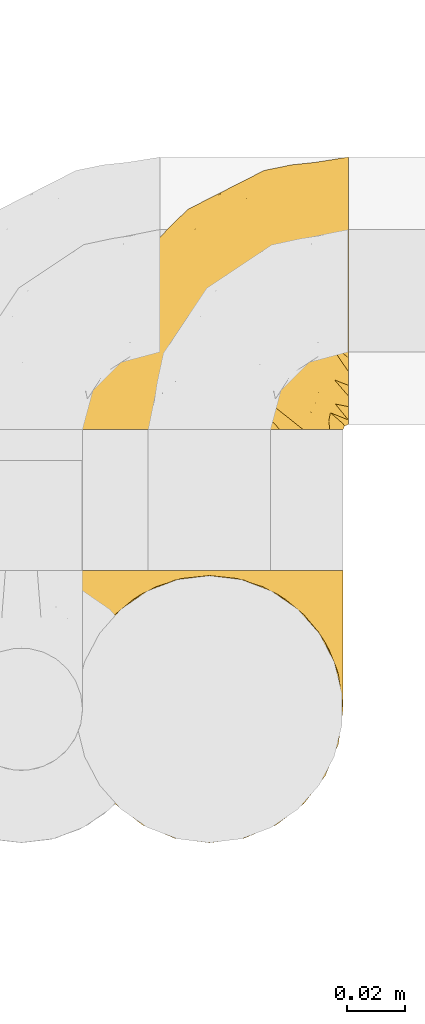
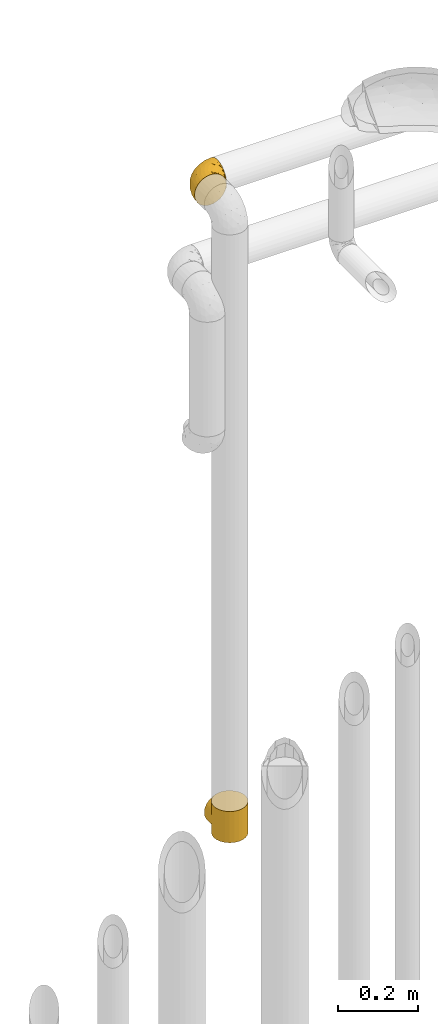
# One storey, part 511 of 827: 2 coverings.
"""IFC2X3 building model written with IfcOpenShell, lengths in millimetres."""

from ifc_helpers import new_model, entity, si_unit, converted_unit, derived_unit, direction, frame, origin, place, context, subcontext, project, spatial, faceted_brep, element, save


model = new_model("IFC2X3")

# Units and contexts
model_context = context("Model", 3, precision=0.01, world=origin(), true_north=direction((6.12303176911189e-17, 1.0)))
body_context = subcontext(model_context, "Body", "Model", "MODEL_VIEW")
ifc_project = project(units=[si_unit("LENGTHUNIT", "METRE", prefix="MILLI"), si_unit("AREAUNIT", "SQUARE_METRE"), si_unit("VOLUMEUNIT", "CUBIC_METRE"), converted_unit("PLANEANGLEUNIT", "DEGREE", entity("IfcRatioMeasure", 0.0174532925199433), si_unit("PLANEANGLEUNIT", "RADIAN"), dimensions=[0, 0, 0, 0, 0, 0, 0]), si_unit("MASSUNIT", "GRAM", prefix="KILO"), derived_unit("MASSDENSITYUNIT", [(si_unit("MASSUNIT", "GRAM", prefix="KILO"), 1), (si_unit("LENGTHUNIT", "METRE"), -3)]), derived_unit("MOMENTOFINERTIAUNIT", [(si_unit("LENGTHUNIT", "METRE"), 4)]), si_unit("TIMEUNIT", "SECOND"), si_unit("FREQUENCYUNIT", "HERTZ"), si_unit("THERMODYNAMICTEMPERATUREUNIT", "DEGREE_CELSIUS"), derived_unit("THERMALTRANSMITTANCEUNIT", [(si_unit("MASSUNIT", "GRAM", prefix="KILO"), 1), (si_unit("THERMODYNAMICTEMPERATUREUNIT", "KELVIN"), -1), (si_unit("TIMEUNIT", "SECOND"), -3)]), derived_unit("VOLUMETRICFLOWRATEUNIT", [(si_unit("LENGTHUNIT", "METRE"), 3), (si_unit("TIMEUNIT", "SECOND"), -1)]), derived_unit("MASSFLOWRATEUNIT", [(si_unit("MASSUNIT", "GRAM", prefix="KILO"), 1), (si_unit("TIMEUNIT", "SECOND"), -1)]), derived_unit("ROTATIONALFREQUENCYUNIT", [(si_unit("TIMEUNIT", "SECOND"), -1)]), si_unit("ELECTRICCURRENTUNIT", "AMPERE"), si_unit("ELECTRICVOLTAGEUNIT", "VOLT"), si_unit("POWERUNIT", "WATT"), si_unit("FORCEUNIT", "NEWTON", prefix="KILO"), si_unit("ILLUMINANCEUNIT", "LUX"), si_unit("LUMINOUSFLUXUNIT", "LUMEN"), si_unit("LUMINOUSINTENSITYUNIT", "CANDELA"), derived_unit("USERDEFINED", [(si_unit("MASSUNIT", "GRAM", prefix="KILO"), -1), (si_unit("LENGTHUNIT", "METRE"), -2), (si_unit("TIMEUNIT", "SECOND"), 3), (si_unit("LUMINOUSFLUXUNIT", "LUMEN"), 1)]), derived_unit("LINEARVELOCITYUNIT", [(si_unit("LENGTHUNIT", "METRE"), 1), (si_unit("TIMEUNIT", "SECOND"), -1)]), si_unit("PRESSUREUNIT", "PASCAL"), derived_unit("USERDEFINED", [(si_unit("LENGTHUNIT", "METRE"), -2), (si_unit("MASSUNIT", "GRAM", prefix="KILO"), 1), (si_unit("TIMEUNIT", "SECOND"), -2)]), derived_unit("LINEARFORCEUNIT", [(si_unit("MASSUNIT", "GRAM", prefix="KILO"), 1), (si_unit("LENGTHUNIT", "METRE"), 1), (si_unit("TIMEUNIT", "SECOND"), -2), (si_unit("LENGTHUNIT", "METRE"), -1)]), derived_unit("PLANARFORCEUNIT", [(si_unit("MASSUNIT", "GRAM", prefix="KILO"), 1), (si_unit("LENGTHUNIT", "METRE"), 1), (si_unit("TIMEUNIT", "SECOND"), -2), (si_unit("LENGTHUNIT", "METRE"), -2)])], contexts=[model_context])

# Site, building, storey
site_placement = place(None, origin())
site = spatial("IfcSite", under=ifc_project, at=site_placement, CompositionType="ELEMENT")
building_placement = place(site_placement, origin())
building = spatial("IfcBuilding", under=site, at=building_placement, CompositionType="ELEMENT")
storey_placement = place(building_placement, frame((0.0, 0.0, 28200.0)))
storey = spatial("IfcBuildingStorey", under=building, at=storey_placement, Name="08", CompositionType="ELEMENT", Elevation=28200.0)

# Coverings
covering_1_placement = place(storey_placement, frame((60065.38, 18623.67, 421.5)))
element("IfcCovering", 1, at=covering_1_placement, inside=storey, Name=":ADSK_", ObjectType=":ADSK_", PredefinedType="INSULATION", context=body_context, shape_type="Brep", body=[
    faceted_brep([(93.48, 54.7, 41.09), (94.0, 47.8, 0.0), (92.42, 59.75, 0.0), (70.23, 87.94, 7.85), (68.11, 88.96, 0.0), (66.38, 90.09, 5.7), (87.81, 70.9, 0.0), (89.25, 68.19, 27.6), (85.44, 74.57, 21.22), (80.46, 80.46, 0.0), (70.9, 87.81, 0.0), (59.75, 92.42, 0.0), (58.58, 92.61, 3.18), (59.69, 92.25, 3.54), (61.92, 91.53, 4.26), (94.0, 47.8, 48.0), (93.48, 54.7, 54.91), (94.0, 47.8, 96.0), (57.46, 92.97, 2.82), (58.26, 92.62, 0.0), (56.76, 92.81, 0.0), (91.91, 61.53, 34.26), (51.53, 93.5, 0.0), (50.78, 93.6, 0.0), (51.42, 93.61, 2.18), (52.28, 93.4, 0.0), (74.07, 85.79, 10.0), (75.68, 84.13, 0.0), (62.54, 91.27, 0.0), (64.15, 90.81, 4.98), (65.32, 90.11, 0.0), (49.29, 93.8, 0.0), (49.0, 93.87, 1.93), (50.21, 93.74, 2.06), (52.63, 93.48, 2.31), (55.27, 93.01, 0.0), (53.77, 93.21, 0.0), (55.05, 93.23, 2.57), (80.41, 80.52, 15.28), (56.26, 93.1, 2.7), (53.84, 93.36, 2.44), (47.8, 94.0, 0.0), (47.8, 94.0, 1.8), (47.8, 94.0, 96.0), (49.0, 93.87, 94.07), (47.8, 94.0, 94.2), (50.04, 93.7, 0.0), (33.66, 91.53, 4.27), (35.84, 92.42, 0.0), (33.05, 91.27, 0.0), (43.31, 93.4, 0.0), (41.82, 93.21, 0.0), (42.95, 93.48, 2.31), (35.89, 92.25, 3.55), (37.0, 92.61, 3.19), (30.27, 90.11, 0.0), (29.21, 90.09, 5.7), (31.43, 90.81, 4.98), (38.11, 92.97, 2.83), (38.83, 92.81, 0.0), (37.33, 92.62, 0.0), (27.48, 88.96, 0.0), (24.7, 87.81, 0.0), (25.37, 87.94, 7.85), (21.52, 85.8, 10.0), (19.91, 84.13, 0.0), (15.18, 80.52, 15.27), (45.37, 93.74, 2.06), (46.3, 93.8, 0.0), (45.55, 93.7, 0.0), (44.81, 93.6, 0.0), (15.13, 80.46, 0.0), (10.15, 74.58, 21.21), (7.78, 70.9, 0.0), (40.53, 93.23, 2.57), (41.74, 93.35, 2.44), (6.34, 68.2, 27.6), (3.17, 59.75, 0.0), (39.32, 93.1, 2.7), (40.32, 93.01, 0.0), (2.11, 54.7, 41.09), (1.6, 47.8, 0.0), (3.69, 61.54, 34.26), (1.6, 47.8, 48.0), (2.11, 54.7, 54.91), (1.6, 47.8, 96.0), (46.59, 93.87, 1.93), (44.16, 93.61, 2.18), (44.06, 93.5, 0.0), (46.59, 93.87, 94.07), (24.7, 7.78, 96.0), (35.84, 3.17, 96.0), (47.8, 1.6, 96.0), (59.75, 3.17, 96.0), (70.9, 7.78, 96.0), (80.46, 15.13, 96.0), (87.81, 24.7, 96.0), (92.42, 35.84, 96.0), (92.42, 59.75, 96.0), (87.81, 70.9, 96.0), (80.46, 80.46, 96.0), (75.68, 84.13, 96.0), (70.9, 87.81, 96.0), (68.11, 88.96, 96.0), (65.32, 90.11, 96.0), (62.54, 91.27, 96.0), (59.75, 92.42, 96.0), (58.26, 92.62, 96.0), (56.76, 92.81, 96.0), (55.27, 93.01, 96.0), (53.77, 93.21, 96.0), (52.28, 93.4, 96.0), (51.53, 93.5, 96.0), (50.78, 93.6, 96.0), (50.04, 93.7, 96.0), (49.29, 93.8, 96.0), (46.3, 93.8, 96.0), (45.55, 93.7, 96.0), (44.81, 93.6, 96.0), (44.06, 93.5, 96.0), (43.31, 93.4, 96.0), (41.82, 93.21, 96.0), (40.32, 93.01, 96.0), (38.83, 92.81, 96.0), (37.33, 92.62, 96.0), (35.84, 92.42, 96.0), (33.05, 91.27, 96.0), (30.27, 90.11, 96.0), (27.48, 88.96, 96.0), (24.7, 87.81, 96.0), (19.91, 84.13, 96.0), (15.13, 80.46, 96.0), (7.78, 70.9, 96.0), (3.17, 59.75, 96.0), (3.17, 35.84, 96.0), (7.78, 24.7, 96.0), (15.13, 15.13, 96.0), (92.42, 35.84, 0.0), (87.81, 24.7, 0.0), (80.46, 15.13, 0.0), (70.9, 7.78, 0.0), (59.75, 3.17, 0.0), (47.8, 1.6, 0.0), (35.84, 3.17, 0.0), (24.7, 7.78, 0.0), (15.13, 15.13, 0.0), (7.78, 24.7, 0.0), (3.17, 35.84, 0.0), (61.92, 91.53, 91.74), (59.69, 92.25, 92.46), (58.58, 92.61, 92.82), (91.91, 61.53, 61.74), (89.25, 68.19, 68.4), (66.38, 90.09, 90.3), (56.26, 93.1, 93.3), (55.05, 93.23, 93.43), (85.44, 74.57, 74.78), (74.07, 85.79, 86.0), (70.23, 87.94, 88.15), (80.41, 80.52, 80.72), (64.15, 90.81, 91.02), (57.46, 92.97, 93.18), (50.21, 93.74, 93.94), (53.84, 93.36, 93.56), (52.63, 93.48, 93.69), (51.42, 93.61, 93.82), (29.21, 90.09, 90.3), (31.43, 90.81, 91.02), (21.52, 85.8, 86.0), (40.53, 93.23, 93.43), (15.18, 80.52, 80.73), (25.37, 87.94, 88.15), (39.32, 93.1, 93.3), (38.11, 92.97, 93.17), (44.16, 93.61, 93.82), (42.95, 93.48, 93.69), (33.66, 91.53, 91.73), (37.0, 92.61, 92.81), (35.89, 92.25, 92.45), (6.34, 68.2, 68.4), (3.69, 61.54, 61.74), (10.15, 74.58, 74.79), (41.74, 93.35, 93.56), (45.37, 93.74, 93.94), (94.0, 95.8, 48.0), (92.42, 95.8, 36.04), (87.81, 95.8, 24.9), (80.46, 95.8, 15.33), (75.68, 95.8, 11.66), (70.9, 95.8, 7.99), (68.11, 95.8, 6.84), (65.32, 95.8, 5.68), (62.54, 95.8, 4.53), (59.75, 95.8, 3.37), (58.26, 95.8, 3.18), (56.76, 95.8, 2.98), (55.27, 95.8, 2.78), (53.77, 95.8, 2.59), (52.28, 95.8, 2.39), (51.53, 95.8, 2.29), (50.78, 95.8, 2.19), (50.04, 95.8, 2.1), (49.29, 95.8, 2.0), (47.8, 95.8, 1.8), (46.3, 95.8, 2.0), (45.55, 95.8, 2.1), (44.81, 95.8, 2.19), (44.06, 95.8, 2.29), (43.31, 95.8, 2.39), (41.82, 95.8, 2.59), (40.32, 95.8, 2.78), (38.83, 95.8, 2.98), (37.33, 95.8, 3.18), (35.84, 95.8, 3.37), (33.05, 95.8, 4.53), (30.27, 95.8, 5.68), (27.48, 95.8, 6.84), (24.7, 95.8, 7.99), (19.91, 95.8, 11.66), (15.13, 95.8, 15.33), (7.78, 95.8, 24.9), (3.17, 95.8, 36.04), (1.6, 95.8, 48.0), (3.17, 95.8, 59.96), (7.78, 95.8, 71.1), (15.13, 95.8, 80.67), (19.91, 95.8, 84.34), (24.7, 95.8, 88.01), (27.48, 95.8, 89.16), (30.27, 95.8, 90.32), (33.05, 95.8, 91.47), (35.84, 95.8, 92.63), (37.33, 95.8, 92.82), (38.83, 95.8, 93.02), (40.32, 95.8, 93.22), (41.82, 95.8, 93.41), (43.31, 95.8, 93.61), (44.06, 95.8, 93.71), (44.81, 95.8, 93.81), (45.55, 95.8, 93.9), (46.3, 95.8, 94.0), (47.8, 95.8, 94.2), (49.29, 95.8, 94.0), (50.04, 95.8, 93.9), (50.78, 95.8, 93.81), (51.53, 95.8, 93.71), (52.28, 95.8, 93.61), (53.77, 95.8, 93.41), (55.27, 95.8, 93.22), (56.76, 95.8, 93.02), (58.26, 95.8, 92.82), (59.75, 95.8, 92.63), (62.54, 95.8, 91.47), (65.32, 95.8, 90.32), (68.11, 95.8, 89.16), (70.9, 95.8, 88.01), (75.68, 95.8, 84.34), (80.46, 95.8, 80.67), (87.81, 95.8, 71.1), (92.42, 95.8, 59.96)], [[[0, 1, 2]], [[3, 4, 5]], [[2, 6, 7]], [[8, 6, 9]], [[4, 3, 10]], [[8, 7, 6]], [[11, 12, 13, 14]], [[0, 15, 1]], [[15, 16, 17]], [[18, 19, 20]], [[7, 21, 2]], [[0, 2, 21]], [[19, 18, 12]], [[12, 11, 19]], [[22, 23, 24, 25]], [[26, 27, 10]], [[28, 29, 30]], [[28, 11, 14]], [[31, 32, 33]], [[29, 28, 14]], [[34, 25, 24]], [[35, 36, 37]], [[38, 9, 27]], [[38, 27, 26]], [[5, 30, 29]], [[20, 39, 18]], [[5, 4, 30]], [[26, 10, 3]], [[35, 39, 20]], [[9, 38, 8]], [[36, 34, 40, 37]], [[34, 36, 25]], [[39, 35, 37]], [[32, 41, 42]], [[43, 44, 45]], [[23, 33, 24]], [[33, 23, 46, 31]], [[41, 32, 31]], [[47, 48, 49]], [[50, 51, 52]], [[48, 47, 53, 54]], [[55, 56, 57]], [[58, 59, 60]], [[61, 62, 63]], [[49, 57, 47]], [[58, 60, 54]], [[64, 62, 65]], [[66, 64, 65]], [[61, 63, 56]], [[67, 68, 69, 70]], [[65, 71, 66]], [[62, 64, 63]], [[72, 71, 73]], [[51, 74, 75, 52]], [[76, 73, 77]], [[78, 79, 59]], [[59, 58, 78]], [[80, 77, 81]], [[79, 78, 74]], [[76, 72, 73]], [[80, 82, 77]], [[83, 80, 81]], [[84, 83, 85]], [[56, 55, 61]], [[76, 77, 82]], [[57, 49, 55]], [[48, 54, 60]], [[71, 72, 66]], [[74, 51, 79]], [[86, 41, 68]], [[87, 50, 52]], [[70, 87, 67]], [[50, 87, 70, 88]], [[41, 86, 42]], [[89, 43, 45]], [[68, 67, 86]], [[90, 91, 92, 93, 94, 95, 96, 97, 17, 98, 99, 100, 101, 102, 103, 104, 105, 106, 107, 108, 109, 110, 111, 112, 113, 114, 115, 43, 116, 117, 118, 119, 120, 121, 122, 123, 124, 125, 126, 127, 128, 129, 130, 131, 132, 133, 85, 134, 135, 136]], [[1, 137, 138, 139, 140, 141, 142, 143, 144, 145, 146, 147, 81, 77, 73, 71, 65, 62, 61, 55, 49, 48, 60, 59, 79, 51, 50, 88, 70, 69, 68, 41, 31, 46, 23, 22, 25, 36, 35, 20, 19, 11, 28, 30, 4, 10, 27, 9, 6, 2]], [[140, 139, 95, 94]], [[92, 142, 141, 93]], [[141, 140, 94, 93]], [[96, 138, 137, 97]], [[1, 15, 17, 97, 137]], [[95, 139, 138, 96]], [[106, 148, 149, 150]], [[151, 152, 98]], [[153, 104, 103]], [[148, 106, 105]], [[16, 151, 98]], [[109, 154, 155]], [[17, 16, 98]], [[99, 156, 100]], [[99, 98, 152]], [[156, 99, 152]], [[102, 157, 158]], [[106, 150, 107]], [[155, 110, 109]], [[157, 101, 159]], [[105, 160, 148]], [[161, 107, 150]], [[162, 115, 114, 113]], [[157, 102, 101]], [[153, 103, 158]], [[104, 153, 160]], [[159, 101, 100]], [[102, 158, 103]], [[108, 161, 154]], [[110, 155, 163, 164]], [[164, 111, 110]], [[161, 108, 107]], [[160, 105, 104]], [[159, 100, 156]], [[154, 109, 108]], [[44, 43, 115]], [[165, 111, 164]], [[113, 165, 162]], [[111, 165, 113, 112]], [[115, 162, 44]], [[166, 127, 167]], [[166, 128, 127]], [[129, 168, 130]], [[122, 121, 169]], [[170, 130, 168]], [[171, 168, 129]], [[123, 172, 173]], [[119, 118, 174, 120]], [[128, 171, 129]], [[174, 175, 120]], [[126, 125, 176]], [[171, 128, 166]], [[170, 131, 130]], [[125, 177, 178, 176]], [[179, 180, 133]], [[173, 124, 123]], [[177, 125, 124]], [[180, 84, 133]], [[131, 181, 132]], [[181, 131, 170]], [[179, 132, 181]], [[179, 133, 132]], [[121, 175, 182, 169]], [[167, 126, 176]], [[84, 85, 133]], [[126, 167, 127]], [[122, 172, 123]], [[124, 173, 177]], [[116, 89, 183]], [[175, 121, 120]], [[172, 122, 169]], [[118, 183, 174]], [[183, 118, 117, 116]], [[43, 89, 116]], [[83, 81, 147, 134, 85]], [[134, 147, 146, 135]], [[146, 145, 136, 135]], [[136, 145, 144, 90]], [[90, 144, 143, 91]], [[91, 143, 142, 92]], [[184, 185, 186, 187, 188, 189, 190, 191, 192, 193, 194, 195, 196, 197, 198, 199, 200, 201, 202, 203, 204, 205, 206, 207, 208, 209, 210, 211, 212, 213, 214, 215, 216, 217, 218, 219, 220, 221, 222, 223, 224, 225, 226, 227, 228, 229, 230, 231, 232, 233, 234, 235, 236, 237, 238, 239, 240, 241, 242, 243, 244, 245, 246, 247, 248, 249, 250, 251, 252, 253, 254, 255, 256, 257, 258, 259]], [[39, 196, 195]], [[198, 197, 34]], [[193, 14, 13, 12]], [[5, 191, 190]], [[14, 193, 192]], [[190, 189, 3]], [[192, 29, 14]], [[18, 194, 12]], [[26, 189, 188]], [[38, 26, 188]], [[190, 3, 5]], [[33, 202, 201, 200]], [[188, 187, 38]], [[189, 26, 3]], [[8, 187, 186]], [[29, 192, 191]], [[7, 186, 185]], [[193, 12, 194]], [[0, 185, 184]], [[191, 5, 29]], [[7, 8, 186]], [[197, 37, 40, 34]], [[0, 21, 185]], [[15, 0, 184]], [[18, 195, 194]], [[7, 185, 21]], [[196, 39, 37]], [[187, 8, 38]], [[37, 197, 196]], [[195, 18, 39]], [[32, 203, 202]], [[24, 198, 34]], [[200, 24, 33]], [[198, 24, 200, 199]], [[203, 32, 42]], [[202, 33, 32]], [[16, 184, 259]], [[158, 254, 153]], [[259, 258, 152]], [[156, 258, 257]], [[254, 158, 255]], [[156, 152, 258]], [[251, 150, 149, 148]], [[16, 15, 184]], [[161, 250, 249]], [[152, 151, 259]], [[16, 259, 151]], [[250, 161, 150]], [[150, 251, 250]], [[245, 244, 165, 246]], [[157, 256, 255]], [[252, 160, 253]], [[252, 251, 148]], [[242, 44, 162]], [[160, 252, 148]], [[164, 246, 165]], [[248, 247, 155]], [[159, 257, 256]], [[159, 256, 157]], [[153, 253, 160]], [[249, 154, 161]], [[153, 254, 253]], [[157, 255, 158]], [[248, 154, 249]], [[257, 159, 156]], [[247, 164, 163, 155]], [[164, 247, 246]], [[154, 248, 155]], [[44, 241, 45]], [[244, 162, 165]], [[162, 244, 243, 242]], [[241, 44, 242]], [[176, 231, 230]], [[236, 235, 175]], [[231, 176, 178, 177]], [[229, 166, 167]], [[173, 233, 232]], [[228, 227, 171]], [[230, 167, 176]], [[173, 232, 177]], [[168, 227, 226]], [[170, 168, 226]], [[228, 171, 166]], [[183, 240, 239, 238]], [[226, 225, 170]], [[227, 168, 171]], [[181, 225, 224]], [[235, 169, 182, 175]], [[179, 224, 223]], [[172, 234, 233]], [[233, 173, 172]], [[84, 223, 222]], [[234, 172, 169]], [[179, 181, 224]], [[84, 180, 223]], [[83, 84, 222]], [[166, 229, 228]], [[179, 223, 180]], [[167, 230, 229]], [[231, 177, 232]], [[225, 181, 170]], [[169, 235, 234]], [[89, 241, 240]], [[174, 236, 175]], [[238, 174, 183]], [[236, 174, 238, 237]], [[241, 89, 45]], [[240, 183, 89]], [[80, 222, 221]], [[209, 52, 75, 74]], [[221, 220, 76]], [[72, 220, 219]], [[210, 78, 211]], [[72, 76, 220]], [[63, 216, 56]], [[80, 83, 222]], [[54, 213, 212]], [[76, 82, 221]], [[80, 221, 82]], [[58, 212, 211]], [[216, 63, 217]], [[207, 206, 87, 208]], [[64, 218, 217]], [[204, 86, 67]], [[214, 213, 47]], [[57, 214, 47]], [[212, 58, 54]], [[52, 208, 87]], [[210, 209, 74]], [[66, 219, 218]], [[66, 218, 64]], [[56, 215, 57]], [[211, 78, 58]], [[56, 216, 215]], [[64, 217, 63]], [[213, 54, 53, 47]], [[219, 66, 72]], [[214, 57, 215]], [[52, 209, 208]], [[78, 210, 74]], [[86, 203, 42]], [[206, 67, 87]], [[67, 206, 205, 204]], [[203, 86, 204]]]),
])
covering_2_placement = place(storey_placement, frame((60065.38, 18766.5, 2286.95)))
element("IfcCovering", 2, at=covering_2_placement, inside=storey, Name=":ADSK_", ObjectType=":ADSK_", PredefinedType="INSULATION", context=body_context, shape_type="Brep", body=[
    faceted_brep([(18.98, 1.6, 83.91), (11.67, 1.6, 76.59), (6.17, 1.6, 67.83), (2.75, 1.6, 58.07), (1.6, 1.6, 47.8), (2.75, 1.6, 37.51), (6.17, 1.6, 27.74), (11.68, 1.6, 18.98), (19.0, 1.6, 11.67), (27.76, 1.6, 6.17), (37.52, 1.6, 2.75), (47.8, 1.6, 1.6), (51.94, 1.6, 2.06), (55.01, 1.6, 2.41), (58.08, 1.6, 2.75), (62.96, 1.6, 4.46), (67.85, 1.6, 6.17), (72.23, 1.6, 8.93), (76.61, 1.6, 11.68), (80.26, 1.6, 15.34), (83.92, 1.6, 19.0), (89.42, 1.6, 27.76), (91.13, 1.6, 32.64), (92.84, 1.6, 37.52), (94.0, 1.6, 47.8), (92.84, 1.6, 58.08), (91.13, 1.6, 62.96), (89.42, 1.6, 67.85), (83.91, 1.6, 76.61), (80.25, 1.6, 80.26), (76.59, 1.6, 83.92), (72.21, 1.6, 86.67), (67.83, 1.6, 89.42), (62.95, 1.6, 91.13), (58.07, 1.6, 92.84), (55.0, 1.6, 93.18), (51.94, 1.6, 93.53), (47.8, 1.6, 94.0), (37.51, 1.6, 92.84), (27.74, 1.6, 89.42), (95.8, 3.4, 47.8), (95.8, 4.97, 35.84), (95.8, 9.58, 24.7), (95.8, 13.26, 19.91), (95.8, 16.93, 15.13), (95.8, 21.71, 11.46), (95.8, 26.5, 7.78), (95.8, 32.07, 5.48), (95.8, 37.64, 3.17), (95.8, 41.25, 2.69), (95.8, 43.34, 2.42), (95.8, 45.42, 2.14), (95.8, 49.6, 1.6), (95.8, 61.55, 3.17), (95.8, 72.7, 7.78), (95.8, 82.26, 15.13), (95.8, 89.61, 24.7), (95.8, 94.22, 35.84), (95.8, 95.8, 47.8), (95.8, 94.22, 59.75), (95.8, 89.61, 70.9), (95.8, 82.26, 80.46), (95.8, 72.7, 87.81), (95.8, 61.55, 92.42), (95.8, 49.6, 94.0), (95.8, 45.42, 93.45), (95.8, 41.25, 92.9), (95.8, 37.64, 92.42), (95.8, 32.07, 90.11), (95.8, 26.5, 87.81), (95.8, 21.71, 84.13), (95.8, 16.93, 80.46), (95.8, 13.26, 75.68), (95.8, 9.58, 70.9), (95.8, 4.97, 59.75), (60.58, 81.55, 71.98), (74.11, 90.4, 63.6), (51.59, 83.0, 59.72), (66.69, 91.18, 47.8), (76.19, 93.13, 55.16), (84.43, 94.0, 47.8), (31.2, 66.19, 63.76), (42.88, 70.92, 72.22), (79.41, 85.95, 74.18), (60.7, 49.74, 92.52), (61.85, 35.54, 94.0), (65.75, 38.14, 94.0), (69.64, 40.74, 94.0), (73.53, 43.34, 94.0), (77.43, 45.94, 94.0), (74.59, 77.59, 82.14), (54.72, 71.17, 80.34), (64.18, 65.81, 87.52), (37.94, 59.03, 79.59), (25.89, 45.85, 78.25), (34.73, 45.79, 85.01), (42.89, 41.42, 90.25), (49.83, 34.51, 93.2), (48.58, 56.04, 87.23), (22.41, 15.15, 85.55), (78.69, 56.51, 93.0), (81.64, 68.39, 89.31), (6.22, 23.33, 61.31), (12.11, 42.86, 56.86), (14.81, 39.42, 68.34), (21.61, 53.58, 65.71), (22.41, 59.17, 56.99), (30.12, 59.06, 72.15), (10.01, 22.63, 70.34), (15.36, 20.55, 78.36), (3.39, 12.96, 47.8), (19.59, 56.96, 47.8), (30.01, 67.38, 47.8), (41.19, 18.72, 93.06), (48.54, 5.33, 94.0), (49.28, 9.07, 94.0), (49.82, 11.79, 94.0), (50.37, 14.51, 94.0), (50.91, 17.24, 94.0), (51.45, 19.96, 94.0), (31.61, 21.03, 89.88), (80.15, 46.48, 94.0), (82.88, 47.03, 94.0), (85.6, 47.57, 94.0), (88.32, 48.11, 94.0), (90.19, 48.48, 94.0), (92.06, 48.85, 94.0), (6.21, 30.7, 47.8), (54.05, 23.86, 94.0), (56.65, 27.75, 94.0), (59.25, 31.64, 94.0), (24.66, 31.26, 83.7), (40.43, 77.8, 47.8), (35.17, 72.75, 55.9), (12.9, 43.83, 47.8), (53.56, 84.49, 47.8), (85.34, 14.58, 81.75), (78.44, 16.17, 86.43), (84.37, 10.82, 79.8), (89.05, 4.64, 69.84), (82.76, 7.71, 79.5), (86.31, 25.13, 88.08), (83.73, 32.66, 91.6), (77.31, 34.94, 92.93), (87.78, 36.76, 92.43), (87.91, 40.48, 93.24), (81.29, 39.25, 93.36), (93.97, 3.69, 57.25), (70.76, 13.99, 89.41), (63.67, 21.85, 92.89), (62.62, 17.93, 92.66), (90.64, 15.11, 79.58), (84.08, 21.14, 86.51), (76.28, 12.7, 86.29), (77.45, 7.21, 83.91), (91.35, 10.45, 73.94), (88.72, 32.27, 90.94), (71.28, 25.68, 91.94), (68.09, 22.18, 91.98), (91.07, 18.79, 82.79), (57.47, 10.12, 93.16), (70.34, 9.47, 88.76), (62.99, 11.29, 91.89), (94.52, 2.87, 47.8), (76.47, 31.16, 92.22), (69.96, 6.31, 88.56), (89.86, 25.62, 87.72), (78.94, 21.18, 88.33), (73.51, 28.81, 92.18), (89.62, 7.45, 71.78), (84.09, 21.14, 9.09), (86.3, 25.13, 7.51), (91.06, 18.79, 12.8), (88.32, 48.11, 1.6), (92.06, 48.85, 1.6), (82.88, 47.03, 1.6), (85.6, 47.57, 1.6), (93.97, 3.69, 38.35), (89.63, 7.44, 23.84), (50.37, 14.51, 1.6), (49.82, 11.79, 1.6), (48.54, 5.33, 1.6), (49.28, 9.07, 1.6), (82.77, 7.71, 16.1), (70.36, 9.47, 6.84), (77.31, 34.94, 2.66), (76.47, 31.16, 3.37), (69.64, 40.74, 1.6), (65.75, 38.14, 1.6), (87.78, 36.76, 3.16), (87.91, 40.48, 2.35), (89.06, 4.63, 25.77), (90.65, 15.11, 16.02), (85.35, 14.58, 13.85), (73.53, 43.34, 1.6), (77.43, 45.94, 1.6), (81.29, 39.25, 2.23), (77.46, 7.21, 11.69), (76.29, 12.69, 9.31), (57.47, 10.14, 2.43), (63.71, 21.81, 2.71), (68.11, 22.19, 3.61), (70.77, 14.0, 6.18), (71.31, 25.69, 3.66), (78.46, 16.17, 9.17), (69.52, 6.66, 6.77), (62.64, 17.92, 2.93), (91.35, 10.45, 21.66), (59.25, 31.64, 1.6), (84.6, 10.64, 16.09), (62.98, 11.31, 3.7), (51.45, 19.96, 1.6), (54.05, 23.86, 1.6), (56.65, 27.75, 1.6), (83.73, 32.66, 3.99), (80.15, 46.48, 1.6), (88.72, 32.27, 4.65), (61.85, 35.54, 1.6), (73.56, 28.77, 3.43), (78.96, 21.17, 7.27), (91.36, 23.36, 9.46), (50.91, 17.24, 1.6), (62.87, 47.58, 2.4), (76.19, 93.13, 40.43), (73.57, 77.44, 13.57), (56.07, 66.78, 11.3), (49.77, 71.68, 18.65), (44.73, 74.96, 27.26), (60.58, 81.55, 23.61), (47.64, 36.7, 3.07), (78.32, 56.9, 2.69), (51.59, 83.0, 35.87), (74.11, 90.4, 31.99), (76.04, 67.83, 6.71), (79.41, 85.95, 21.41), (14.82, 39.41, 27.24), (6.22, 23.33, 34.26), (12.12, 42.87, 38.73), (23.51, 53.92, 26.97), (31.2, 66.19, 31.83), (34.96, 64.12, 23.4), (33.86, 33.13, 6.91), (38.94, 23.1, 3.4), (30.23, 16.98, 5.84), (35.17, 72.75, 39.69), (15.85, 23.77, 17.6), (22.59, 18.41, 10.38), (21.56, 43.7, 20.6), (55.94, 54.53, 5.36), (20.67, 55.72, 35.73), (9.19, 17.73, 24.84), (25.79, 38.98, 13.87), (41.16, 50.28, 9.06), (37.95, 59.02, 15.99)], [[[0, 1, 2, 3, 4, 5, 6, 7, 8, 9, 10, 11, 12, 13, 14, 15, 16, 17, 18, 19, 20, 21, 22, 23, 24, 25, 26, 27, 28, 29, 30, 31, 32, 33, 34, 35, 36, 37, 38, 39]], [[40, 41, 42, 43, 44, 45, 46, 47, 48, 49, 50, 51, 52, 53, 54, 55, 56, 57, 58, 59, 60, 61, 62, 63, 64, 65, 66, 67, 68, 69, 70, 71, 72, 73, 74]], [[75, 76, 77]], [[78, 79, 80]], [[77, 81, 82]], [[76, 75, 83]], [[84, 85, 86, 87, 88, 89]], [[90, 91, 92]], [[76, 60, 59]], [[93, 94, 95]], [[90, 62, 61]], [[83, 61, 60]], [[96, 97, 84]], [[98, 93, 95]], [[0, 39, 99]], [[100, 84, 89]], [[62, 101, 63]], [[2, 102, 3]], [[92, 84, 100]], [[103, 102, 104]], [[103, 105, 106]], [[93, 107, 94]], [[1, 108, 2]], [[92, 101, 90]], [[108, 1, 109]], [[102, 110, 3]], [[93, 82, 107]], [[102, 108, 104]], [[111, 106, 112]], [[109, 0, 99]], [[113, 37, 114, 115, 116, 117, 118, 119]], [[120, 38, 113]], [[100, 89, 121, 122, 123, 124, 125, 126, 64]], [[127, 102, 103]], [[97, 119, 128, 129, 130, 85]], [[99, 120, 131]], [[132, 133, 77]], [[59, 80, 79]], [[1, 0, 109]], [[98, 84, 92]], [[94, 109, 131]], [[120, 39, 38]], [[93, 91, 82]], [[104, 94, 105]], [[97, 113, 119]], [[95, 120, 96]], [[83, 90, 61]], [[91, 93, 98]], [[64, 63, 100]], [[100, 63, 101]], [[77, 76, 79]], [[133, 106, 81]], [[84, 97, 85]], [[113, 96, 120]], [[113, 97, 96]], [[37, 113, 38]], [[110, 102, 127]], [[110, 4, 3]], [[103, 111, 134, 127]], [[90, 75, 91]], [[82, 81, 107]], [[91, 75, 82]], [[77, 82, 75]], [[76, 83, 60]], [[90, 83, 75]], [[105, 107, 81]], [[94, 131, 95]], [[105, 94, 107]], [[109, 94, 104]], [[120, 95, 131]], [[98, 95, 96]], [[84, 98, 96]], [[98, 92, 91]], [[106, 105, 81]], [[103, 104, 105]], [[112, 106, 133]], [[103, 106, 111]], [[112, 133, 132]], [[81, 77, 133]], [[77, 78, 135, 132]], [[120, 99, 39]], [[109, 99, 131]], [[59, 58, 80]], [[59, 79, 76]], [[90, 101, 62]], [[100, 101, 92]], [[2, 108, 102]], [[109, 104, 108]], [[78, 77, 79]], [[136, 137, 138]], [[27, 139, 140]], [[141, 142, 143]], [[144, 145, 121]], [[146, 89, 88]], [[147, 139, 25]], [[148, 149, 150]], [[136, 151, 152]], [[147, 40, 74]], [[24, 147, 25]], [[140, 153, 154]], [[33, 116, 34]], [[73, 151, 155]], [[114, 37, 36, 35, 34, 116, 115]], [[146, 156, 144]], [[157, 85, 130]], [[158, 149, 148]], [[151, 159, 152]], [[117, 33, 160]], [[29, 154, 161]], [[155, 74, 73]], [[162, 128, 119]], [[66, 65, 64, 126, 125, 124, 123, 122, 67]], [[163, 147, 24]], [[27, 140, 28]], [[149, 129, 150]], [[139, 27, 26, 25]], [[68, 144, 69]], [[129, 128, 150]], [[164, 87, 86]], [[130, 129, 149]], [[122, 145, 67]], [[154, 153, 148]], [[162, 119, 160]], [[165, 30, 161]], [[150, 161, 148]], [[128, 162, 150]], [[30, 165, 31]], [[145, 144, 68]], [[89, 146, 144]], [[87, 164, 143]], [[166, 156, 142]], [[88, 87, 143]], [[162, 161, 150]], [[161, 30, 29]], [[154, 29, 28]], [[140, 154, 28]], [[161, 154, 148]], [[140, 137, 153]], [[158, 148, 153]], [[157, 130, 158]], [[153, 137, 158]], [[158, 137, 157]], [[167, 137, 136]], [[168, 85, 157]], [[152, 168, 167]], [[167, 168, 157]], [[164, 152, 141]], [[151, 73, 72]], [[159, 72, 71]], [[88, 142, 146]], [[144, 156, 69]], [[146, 142, 156]], [[70, 166, 71]], [[142, 141, 166]], [[70, 69, 156]], [[141, 159, 71]], [[167, 136, 152]], [[138, 137, 140]], [[155, 136, 169]], [[136, 155, 151]], [[74, 155, 169]], [[152, 159, 141]], [[151, 72, 159]], [[168, 152, 164]], [[137, 167, 157]], [[164, 86, 168]], [[85, 168, 86]], [[116, 33, 117]], [[130, 149, 158]], [[67, 145, 68]], [[121, 89, 144]], [[145, 122, 121]], [[40, 147, 163]], [[169, 147, 74]], [[160, 33, 32]], [[162, 160, 32]], [[160, 119, 118, 117]], [[139, 147, 169]], [[139, 169, 138]], [[162, 32, 31]], [[141, 143, 164]], [[88, 143, 142]], [[71, 166, 141]], [[156, 166, 70]], [[139, 138, 140]], [[169, 136, 138]], [[161, 162, 165]], [[162, 31, 165]], [[170, 171, 172]], [[173, 174, 52, 51, 50, 49, 48, 175, 176]], [[177, 178, 41]], [[179, 15, 180]], [[12, 11, 181, 182, 180, 14, 13]], [[183, 21, 20]], [[19, 18, 184]], [[185, 186, 187]], [[186, 188, 187]], [[43, 172, 44]], [[189, 190, 47]], [[23, 22, 21, 191]], [[170, 192, 193]], [[40, 163, 177]], [[194, 195, 196]], [[24, 23, 177]], [[197, 198, 183]], [[199, 15, 179]], [[178, 177, 191]], [[47, 46, 189]], [[200, 201, 202]], [[201, 203, 204]], [[205, 206, 184]], [[207, 41, 178]], [[16, 15, 199]], [[14, 180, 15]], [[202, 201, 198]], [[208, 201, 200]], [[163, 24, 177]], [[48, 47, 190]], [[196, 195, 189]], [[197, 184, 202]], [[204, 193, 209]], [[210, 211, 212]], [[206, 212, 213]], [[205, 17, 210]], [[184, 206, 202]], [[210, 212, 206]], [[185, 194, 214]], [[189, 215, 190]], [[216, 45, 214]], [[186, 171, 170]], [[189, 216, 196]], [[197, 20, 19]], [[194, 185, 187]], [[197, 183, 20]], [[184, 197, 19]], [[197, 202, 198]], [[206, 200, 202]], [[204, 183, 198]], [[201, 208, 203]], [[203, 208, 217]], [[204, 198, 201]], [[217, 188, 218]], [[193, 219, 170]], [[171, 186, 185]], [[170, 218, 186]], [[170, 219, 218]], [[42, 207, 192]], [[171, 220, 172]], [[216, 189, 46]], [[214, 194, 196]], [[44, 220, 45]], [[214, 196, 216]], [[216, 46, 45]], [[214, 45, 220]], [[192, 43, 42]], [[204, 203, 219]], [[207, 193, 192]], [[209, 193, 178]], [[41, 207, 42]], [[193, 207, 178]], [[43, 192, 172]], [[170, 172, 192]], [[204, 219, 193]], [[219, 203, 218]], [[217, 218, 203]], [[188, 186, 218]], [[206, 213, 200]], [[208, 200, 213]], [[199, 210, 16]], [[215, 189, 195]], [[215, 175, 190]], [[175, 48, 190]], [[199, 179, 221, 211]], [[210, 199, 211]], [[23, 191, 177]], [[40, 177, 41]], [[191, 183, 209]], [[21, 183, 191]], [[205, 18, 17]], [[17, 16, 210]], [[171, 185, 214]], [[172, 220, 44]], [[214, 220, 171]], [[191, 209, 178]], [[204, 209, 183]], [[206, 205, 210]], [[18, 205, 184]], [[222, 195, 194, 187, 188, 217]], [[57, 223, 80]], [[224, 225, 226]], [[226, 227, 228]], [[229, 217, 208, 213, 212, 211]], [[230, 52, 174, 173, 176, 175, 215, 195]], [[231, 232, 228]], [[231, 78, 223]], [[223, 57, 232]], [[224, 233, 225]], [[233, 54, 53]], [[234, 232, 56]], [[56, 55, 234]], [[234, 224, 228]], [[235, 236, 237]], [[224, 55, 54]], [[238, 239, 240]], [[52, 230, 53]], [[241, 242, 243]], [[231, 227, 244]], [[11, 10, 242]], [[236, 6, 5]], [[7, 245, 8]], [[8, 246, 9]], [[238, 247, 235]], [[222, 229, 248]], [[242, 211, 221, 179, 180, 182, 181, 11]], [[233, 53, 230]], [[111, 112, 249]], [[250, 6, 236]], [[246, 251, 241]], [[6, 250, 7]], [[127, 236, 110]], [[248, 229, 252]], [[246, 8, 245]], [[235, 245, 250]], [[236, 5, 110]], [[235, 249, 238]], [[237, 236, 127]], [[243, 9, 246]], [[252, 229, 241]], [[56, 232, 57]], [[222, 230, 195]], [[225, 248, 252]], [[248, 233, 230]], [[54, 233, 224]], [[231, 228, 227]], [[244, 132, 231]], [[248, 225, 233]], [[226, 225, 253]], [[235, 250, 236]], [[245, 7, 250]], [[251, 246, 245]], [[243, 246, 241]], [[247, 245, 235]], [[252, 251, 253]], [[229, 222, 217]], [[230, 222, 248]], [[5, 4, 110]], [[237, 127, 134, 111]], [[238, 249, 239]], [[224, 234, 55]], [[232, 234, 228]], [[242, 241, 229]], [[10, 9, 243]], [[211, 242, 229]], [[10, 243, 242]], [[80, 223, 78]], [[80, 58, 57]], [[231, 223, 232]], [[227, 240, 239]], [[224, 226, 228]], [[240, 226, 253]], [[227, 239, 244]], [[226, 240, 227]], [[251, 247, 253]], [[240, 253, 247]], [[249, 235, 237]], [[237, 111, 249]], [[244, 239, 249]], [[112, 244, 249]], [[135, 78, 231, 132]], [[112, 132, 244]], [[247, 238, 240]], [[245, 247, 251]], [[251, 252, 241]], [[225, 252, 253]]]),
])

save(model, "model.ifc")
